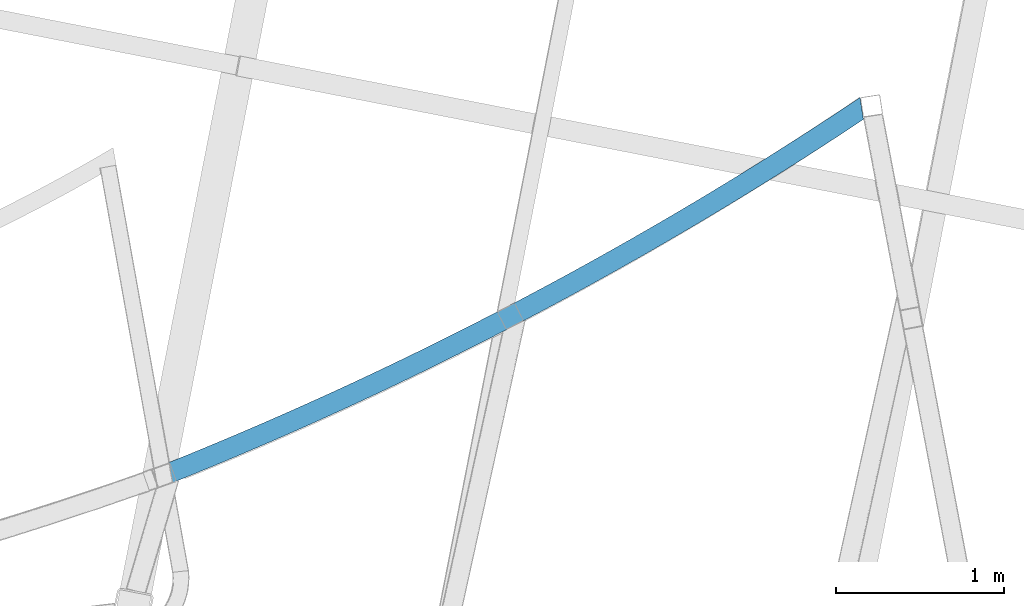
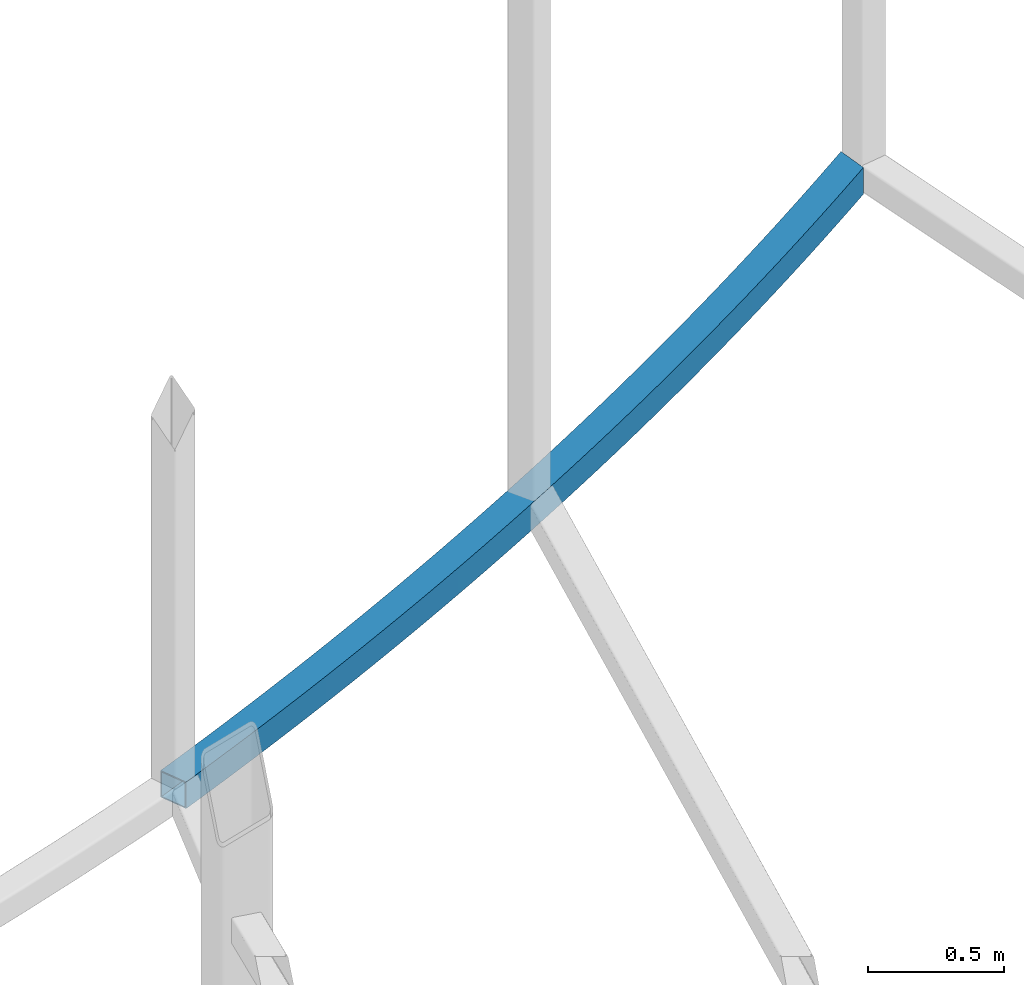
# One storey, part 211 of 215: 1 beam, 1 element without a shape of its own.
"""IFC2X3 building model written with IfcOpenShell, lengths in millimetres."""

from ifc_helpers import new_model, si_unit, frame, origin_with_axes, place, context, subcontext, project, spatial, faceted_brep, material, type_object, element, aggregate, save


model = new_model("IFC2X3")

# Units and contexts
model_context = context("Model", 3, precision=1e-05, world=origin_with_axes())
body_context = subcontext(model_context, "Body", "Model", "MODEL_VIEW")
ifc_project = project(units=[si_unit("LENGTHUNIT", "METRE", prefix="MILLI"), si_unit("AREAUNIT", "SQUARE_METRE"), si_unit("VOLUMEUNIT", "CUBIC_METRE"), si_unit("MASSUNIT", "GRAM", prefix="KILO"), si_unit("TIMEUNIT", "SECOND"), si_unit("PLANEANGLEUNIT", "RADIAN"), si_unit("SOLIDANGLEUNIT", "STERADIAN"), si_unit("THERMODYNAMICTEMPERATUREUNIT", "DEGREE_CELSIUS"), si_unit("LUMINOUSINTENSITYUNIT", "LUMEN")], contexts=[model_context])

# Site, building, storey
site_placement = place(None, origin_with_axes())
site = spatial("IfcSite", under=ifc_project, at=site_placement, CompositionType="ELEMENT")
building_placement = place(site_placement, origin_with_axes())
building = spatial("IfcBuilding", under=site, at=building_placement, Name="Undefined", CompositionType="ELEMENT")
storey_placement = place(building_placement, origin_with_axes())
storey = spatial("IfcBuildingStorey", under=building, at=storey_placement, Name="Undefined", CompositionType="ELEMENT", Elevation=0.0)

# Assembly, beam
assembly_placement = place(storey_placement, origin_with_axes())
assembly = element("IfcElementAssembly", 1, at=assembly_placement, inside=storey, Name="Steel Assembly", AssemblyPlace="NOTDEFINED", PredefinedType="RIGID_FRAME")
ifc_material = material(Name="STEEL/S275JR")
beam_type = type_object("IfcBeamType", PredefinedType="NOTDEFINED")
beam_placement = place(assembly_placement, frame((89086.1662001797, 7629.35720790217, 8706.00006129924), z_axis=(0.0, 0.0, -1.0), x_axis=(-0.884819292057938, -0.465934352030508, 6.99999985050166e-09)))
beam = element("IfcBeam", 2, at=beam_placement, type_object=beam_type, material=ifc_material, Name="LISSE", context=body_context, shape_type="Brep", body=[
    faceted_brep([(100.008088549963, 50.0191894137461, -60.0000000000018), (100.00808859081, 50.0191894137533, 59.9999999999982), (193.785047622063, 40.7596308906723, 60.0), (193.78504758123, 40.759630890665, -60.0), (287.59996438674, 31.8929031047883, 59.9999999999982), (287.599964345907, 31.8929031047883, -60.0000000000018), (381.451193328117, 23.4191615826057, 59.9999999999982), (381.451193287285, 23.4191615825985, -60.0000000000018), (475.337088252578, 15.3385549574232, 59.9999999999982), (475.337088211731, 15.3385549574159, -60.0000000000018), (569.256002358336, 7.65122496679396, 59.9999999999982), (569.256002317503, 7.65122496680124, -60.0000000000018), (663.20628826457, 0.357306450037868, 60.0), (663.206288223737, 0.357306450037868, -60.0), (757.18629804012, -6.54307265418902, 59.9999999999982), (757.186297999287, -6.54307265419629, -60.0000000000018), (851.194383232432, -13.0497913100626, 60.0), (851.194383191614, -13.0497913100626, -60.0), (945.228894896543, -19.1627353867516, 60.0), (945.228894855711, -19.1627353867516, -60.0), (1039.28818362394, -24.8817976603968, 59.9999999999982), (1039.28818358311, -24.8817976604041, -60.0000000000018), (1133.3705995715, -30.2068778160392, 59.9999999999982), (1133.37059953065, -30.2068778160465, -60.0000000000018), (1227.47449249044, -35.1378824493222, 59.9999999999982), (1227.4744924496, -35.1378824493149, -60.0000000000018), (1321.59821175526, -39.6747250681437, 60.0), (1321.59821171444, -39.6747250681437, -60.0), (1415.74010639274, -43.8173260942131, 59.9999999999982), (1415.74010635189, -43.8173260942203, -60.0000000000018), (1509.89852511077, -47.5656128644187, 60.0), (1509.89852506993, -47.5656128644187, -60.0), (1604.07181632749, -50.9195196320652, 60.0), (1604.07181628664, -50.9195196320725, -60.0), (1698.25832820007, -53.8789875681032, 60.0), (1698.25832815925, -53.8789875681032, -60.0), (1792.4564086539, -56.4439647621039, 59.9999999999982), (1792.45640861308, -56.4439647621039, -60.0000000000018), (1886.6644054114, -58.6144062231833, 60.0), (1886.66440537057, -58.6144062231833, -60.0), (1980.880666021, -60.3902738808101, 59.9999999999982), (1980.88066598016, -60.3902738808174, -60.0000000000018), (2075.10353788624, -61.7715365854383, 59.9999999999982), (2075.1035378454, -61.7715365854456, -60.0000000000018), (2169.33136829468, -62.7581701091112, 59.9999999999982), (2169.33136825384, -62.7581701091112, -60.0000000000018), (2263.56250444692, -63.3501571457964, 60.0), (2263.56250440607, -63.3501571457891, -60.0), (2357.79529348554, -63.547487311771, 60.0), (2357.79529344471, -63.5474873117782, -60.0), (2452.02808252416, -63.3501571457891, 60.0), (2452.02808248333, -63.3501571457964, -60.0), (2546.25921867639, -62.7581701091112, 59.9999999999982), (2546.25921863558, -62.7581701091112, -60.0000000000018), (2640.48704908486, -61.7715365854383, 59.9999999999982), (2640.48704904401, -61.7715365854456, -60.0000000000018), (2734.7099209501, -60.3902738808101, 59.9999999999982), (2734.70992090924, -60.3902738808174, -60.0000000000018), (2828.9261815597, -58.6144062231833, 59.9999999999982), (2828.92618151884, -58.6144062231906, -60.0000000000018), (2923.13417831717, -56.4439647621039, 60.0), (2923.13417827633, -56.4439647621039, -60.0), (3017.332258771, -53.8789875681105, 60.0), (3017.33225873017, -53.8789875681032, -60.0), (3111.5187706436, -50.9195196320652, 60.0), (3111.51877060278, -50.9195196320652, -60.0), (3205.69206186032, -47.5656128644114, 59.9999999999982), (3205.69206181949, -47.5656128644187, -60.0000000000018), (3299.85048057835, -43.8173260942131, 60.0), (3299.85048053751, -43.8173260942131, -60.0), (3393.99237521581, -39.6747250681437, 60.0), (3393.99237517497, -39.6747250681437, -60.0), (3488.11609448065, -35.1378824493149, 59.9999999999982), (3488.11609443981, -35.1378824493149, -60.0000000000018), (3582.21998739959, -30.2068778160392, 59.9999999999982), (3582.21998735875, -30.2068778160465, -60.0000000000018), (3676.30240334714, -24.8817976603968, 60.0), (3676.3024033063, -24.8817976604041, -60.0), (3770.36169207454, -19.1627353867443, 60.0), (3770.36169203369, -19.1627353867516, -60.0), (3864.39620373865, -13.0497913100626, 59.9999999999982), (3864.3962036978, -13.0497913100699, -60.0000000000018), (3958.40428893096, -6.54307265419629, 59.9999999999982), (3958.40428889013, -6.54307265419629, -60.0000000000018), (4052.38429870651, 0.357306450037868, 60.0), (4052.38429866567, 0.357306450030592, -60.0), (4146.33458461275, 7.65122496680124, 59.9999999999982), (4146.3345845719, 7.65122496680124, -60.0000000000018), (4240.25349871852, 15.3385549574232, 60.0), (4240.25349867767, 15.3385549574159, -60.0), (4334.13939364295, 23.4191615826057, 59.9999999999982), (4334.13939360212, 23.4191615825985, -60.0000000000018), (4427.99062258434, 31.8929031047883, 60.0), (4427.9906225435, 31.892903104781, -60.0), (4521.80553934902, 40.7596308906723, 59.9999999999982), (4521.80553930817, 40.759630890665, -60.0000000000018), (4615.58249838027, 50.0191894137533, 59.9999999999982), (4615.58249833946, 50.0191894137533, -60.0000000000018), (4533.34692732696, -78.6840644789263, 59.9999999999982), (4627.62403013972, -69.3751216437086, 59.9999999999982), (4439.03166433953, -87.5980814796567, 59.9999999999982), (4344.67989551046, -96.1170162899653, 59.9999999999982), (4250.29327581309, -104.240719483816, 60.0), (4155.8734608321, -111.969048567713, 60.0), (4061.42210673436, -119.301867983231, 59.9999999999982), (3966.94087024, -126.239049109354, 59.9999999999982), (3872.43140859333, -132.780470264719, 59.9999999999982), (3777.89537953369, -138.926016709811, 59.9999999999982), (3683.33444126642, -144.675580648924, 60.0), (3588.75025243381, -150.02906123206, 59.9999999999982), (3494.14447208596, -154.986364556717, 59.9999999999982), (3399.51875965172, -159.547403669509, 60.0), (3304.87477490951, -163.712098567725, 59.9999999999982), (3210.21417795832, -167.4803762007, 59.9999999999982), (3115.53862918845, -170.852170471109, 60.0), (3020.84978925253, -173.827422236136, 60.0), (2926.14931903627, -176.406079308501, 60.0), (2831.43887962942, -178.588096457373, 59.9999999999982), (2736.72013229658, -180.373435409179, 59.9999999999982), (2641.99473844805, -181.762064848241, 59.9999999999982), (2547.26435961077, -182.753960417358, 60.0), (2452.53065739904, -183.34910471824, 59.9999999999982), (2357.79529348554, -183.547487311778, 59.9999999999982), (2263.05992957203, -183.349104718247, 59.9999999999982), (2168.32622736033, -182.753960417358, 60.0), (2073.59584852302, -181.762064848241, 60.0), (1978.87045467451, -180.373435409172, 59.9999999999982), (1884.15170734168, -178.588096457381, 60.0), (1789.44126793482, -176.406079308508, 60.0), (1694.74079771856, -173.827422236136, 59.9999999999982), (1600.05195778262, -170.852170471109, 59.9999999999982), (1505.37640901278, -167.4803762007, 59.9999999999982), (1410.71581206158, -163.712098567725, 59.9999999999982), (1316.07182731938, -159.547403669509, 59.9999999999982), (1221.44611488513, -154.986364556717, 60.0), (1126.84033453729, -150.029061232053, 59.9999999999982), (1032.25614570468, -144.675580648924, 60.0), (937.695207437413, -138.926016709811, 59.9999999999982), (843.159178377755, -132.780470264726, 59.9999999999982), (748.649716731074, -126.239049109347, 59.9999999999982), (654.168480236724, -119.301867983231, 59.9999999999982), (559.717126139003, -111.969048567713, 59.9999999999982), (465.297311157992, -104.240719483809, 59.9999999999982), (370.910691460624, -96.1170162899653, 60.0), (276.55892263155, -87.5980814796567, 60.0), (182.243659644126, -78.684064478919, 59.9999999999982), (87.9665568313649, -69.3751216437158, 60.0), (87.9665567905322, -69.3751216437086, -60.0), (182.243659603293, -78.684064478919, -60.0000000000018), (276.558922590717, -87.5980814796567, -60.0), (370.910691419791, -96.117016289958, -60.0), (465.29731111716, -104.240719483816, -60.0000000000018), (559.717126098156, -111.96904856772, -60.0000000000018), (654.168480195891, -119.301867983231, -60.0000000000018), (748.649716690241, -126.239049109354, -60.0000000000018), (843.159178336922, -132.780470264726, -60.0000000000018), (937.695207396566, -138.926016709818, -60.0000000000018), (1032.25614566384, -144.675580648931, -60.0), (1126.84033449645, -150.029061232068, -60.0000000000018), (1221.44611484431, -154.986364556717, -60.0), (1316.07182727855, -159.547403669516, -60.0000000000018), (1410.71581202073, -163.712098567732, -60.0000000000018), (1505.37640897193, -167.480376200692, -60.0000000000018), (1600.0519577418, -170.852170471109, -60.0000000000018), (1694.74079767773, -173.827422236136, -60.0000000000018), (1789.44126789398, -176.406079308508, -60.0), (1884.15170730083, -178.588096457388, -60.0), (1978.87045463368, -180.373435409179, -60.0000000000018), (2073.5958484822, -181.762064848241, -60.0), (2168.3262273195, -182.753960417365, -60.0), (2263.05992953121, -183.349104718247, -60.0000000000018), (2357.79529344471, -183.547487311786, -60.0000000000018), (2452.53065735822, -183.34910471824, -60.0000000000018), (2547.2643595699, -182.753960417365, -60.0), (2641.99473840721, -181.762064848241, -60.0000000000018), (2736.72013225574, -180.373435409187, -60.0000000000018), (2831.43887958859, -178.588096457381, -60.0000000000018), (2926.14931899543, -176.406079308501, -60.0), (3020.84978921169, -173.827422236143, -60.0), (3115.53862914762, -170.852170471109, -60.0), (3210.21417791747, -167.4803762007, -60.0000000000018), (3304.87477486869, -163.712098567717, -60.0000000000018), (3399.51875961086, -159.547403669516, -60.0), (3494.14447204511, -154.986364556717, -60.0000000000018), (3588.75025239296, -150.029061232068, -60.0000000000018), (3683.33444122557, -144.675580648931, -60.0), (3777.89537949284, -138.926016709818, -60.0000000000018), (3872.43140855248, -132.780470264726, -60.0000000000018), (3966.94087019918, -126.239049109354, -60.0000000000018), (4061.42210669351, -119.301867983238, -60.0000000000018), (4155.87346079125, -111.96904856772, -60.0), (4250.29327577226, -104.240719483816, -60.0), (4344.67989546963, -96.1170162899653, -60.0000000000018), (4439.03166429869, -87.598081479664, -60.0000000000018), (4533.34692728613, -78.684064478919, -60.0000000000018), (4627.62403009889, -69.3751216437158, -60.0000000000018), (4721.86131907329, -59.6714162571589, -60.0000000000018), (4721.86131911415, -59.6714162571516, 59.9999999999982), (4709.31985478719, 59.6714162571516, 59.9999999999982), (4709.31985474635, 59.6714162571443, -60.0000000000018), (99.5063580991264, 45.0444264530233, 55.0), (88.4682873196434, -64.4003586829858, 55.0), (47.6512828940467, -60.1973920015589, 55.0), (8.13784636146738, 54.4527310547419, 54.9999999999982), (88.4682872822159, -64.4003586829858, -55.0), (47.6512828953855, -60.1973920055389, -55.0), (99.5063580616843, 45.0444264530233, -55.0), (8.13784636282071, 54.4527310507401, -55.0000000000018), (193.304156417173, 35.7828102502681, -55.0000000000018), (193.304156454615, 35.7828102502608, 54.9999999999982), (182.724550808169, -73.7072438385148, 55.0), (182.724550770712, -73.7072438385221, -55.0), (277.018965998883, -82.61929045531, -55.0000000000018), (287.139920941132, 26.9141120804343, -55.0), (287.139920978574, 26.9141120804343, 55.0), (277.01896603631, -82.61929045531, 54.9999999999982), (371.34987903673, -91.1363422119393, 55.0), (371.349878999288, -91.1363422119393, -55.0), (381.012005711164, 18.4384875045798, -55.0000000000018), (381.012005748606, 18.4384875045725, 54.9999999999982), (474.918764205242, 10.3560851890361, 54.9999999999982), (465.715635201894, -99.2582497154217, 54.9999999999982), (465.715635164437, -99.258249715429, -55.0000000000018), (474.918764167815, 10.3560851890361, -55.0000000000018), (568.858549143377, 2.66704690286133, -55.0000000000018), (568.858549180834, 2.66704690286133, 54.9999999999982), (560.1145793131, -106.98487050378, 54.9999999999982), (560.114579275658, -106.98487050378, -55.0000000000018), (654.545055532071, -114.316069048509, -55.0000000000018), (662.829712890947, -4.62849248467683, -55.0000000000018), (662.829712928375, -4.62849248467683, 54.9999999999982), (654.545055569513, -114.316069048517, 54.9999999999982), (749.005407617253, -121.251716757055, 55.0), (749.005407579811, -121.251716757055, -55.0), (756.830607113094, -11.5304050064951, -55.0), (756.830607150536, -11.5304050064951, 55.0), (850.859583028447, -18.0385695998411, 55.0), (843.493978578321, -127.791691974948, 55.0), (843.493978540893, -127.79169197494, -55.0), (850.859582991005, -18.0385695998411, -55.0), (944.914991213271, -24.1528721085415, -55.0000000000018), (944.914991250727, -24.1528721085415, 54.9999999999982), (938.009111079824, -133.935879988021, 54.9999999999982), (938.009111042396, -133.935879988021, -55.0000000000018), (1032.5491472455, -139.684173024412, -55.0000000000018), (1038.99518200482, -29.8732052849227, -55.0000000000018), (1038.99518204226, -29.8732052849227, 54.9999999999982), (1032.54914728295, -139.684173024405, 54.9999999999982), (1127.11242891201, -145.036470256397, 55.0), (1127.11242887458, -145.036470256397, -55.0), (1133.09850515594, -35.1994687917104, -55.0), (1133.09850519337, -35.1994687917104, 55.0), (1227.22331008851, -40.131569203797, 55.0), (1221.69729728365, -149.992677802242, 54.9999999999982), (1221.6972972462, -149.992677802242, -55.0000000000018), (1227.22331005106, -40.1315692037897, -55.0), (1321.36794569796, -44.6694200098646, -55.0), (1321.36794573542, -44.6694200098646, 55.0), (1316.30209333583, -154.552708727788, 55.0), (1316.30209329839, -154.552708727788, -55.0), (1410.92515761955, -158.716483047996, -55.0000000000018), (1415.53076075646, -48.8129416139491, -55.0000000000018), (1415.5307607939, -48.8129416139491, 54.9999999999982), (1410.925157657, -158.716483047996, 54.9999999999982), (1505.56483051516, -162.483927728354, 55.0), (1505.5648304777, -162.483927728361, -55.0), (1509.71010356754, -52.5620613367646, -55.0000000000018), (1509.710103605, -52.5620613367573, 54.9999999999982), (1603.90432221974, -55.9167134170275, 55.0), (1600.21945188697, -165.854976686147, 54.9999999999982), (1600.21945184952, -165.854976686154, -55.0000000000018), (1603.90432218229, -55.9167134170275, -55.0), (1698.11176439088, -58.8768390126133, -55.0), (1698.11176442832, -58.8768390126061, 55.0), (1694.88736148692, -168.829570791633, 54.9999999999982), (1694.88736144948, -168.82957079164, -55.0000000000018), (1789.56689875896, -171.407657869066, -55.0000000000018), (1792.33077775147, -61.4423862015392, -55.0), (1792.33077778891, -61.4423862015392, 55.0), (1789.56689879642, -171.407657869073, 54.9999999999982), (1884.25640309288, -173.589192697626, 54.9999999999982), (1884.25640305543, -173.589192697618, -55.0000000000018), (1886.55970961934, -63.6133099829458, -55.0000000000018), (1886.55970965679, -63.6133099829458, 54.9999999999982), (1980.7969072132, -65.3895722778252, 55.0), (1978.95421347891, -175.374137012164, 55.0), (1978.95421344147, -175.374137012164, -55.0), (1980.79690717574, -65.3895722778252, -55.0), (2075.04071745696, -66.7711419297266, -55.0000000000018), (2075.0407174944, -66.7711419297266, 54.9999999999982), (2073.65866891146, -176.762459503967, 54.9999999999982), (2073.65866887402, -176.76245950396, -55.0000000000018), (2168.36810819343, -177.754135821189, -55.0), (2169.28948738327, -67.7579947052873, -55.0000000000018), (2169.2894874207, -67.7579947052873, 54.9999999999982), (2168.36810823089, -177.754135821182, 55.0), (2263.08087019013, -178.349148569388, 55.0), (2263.08087015268, -178.349148569388, -55.0), (2263.54156378799, -68.3501132946403, -55.0), (2263.54156382543, -68.3501132946476, 55.0), (2357.79529348384, -68.5474873117782, 55.0), (2357.79529348384, -178.547487311771, 54.9999999999982), (2357.7952934464, -178.547487311778, -55.0000000000018), (2357.7952934464, -68.5474873117855, -55.0), (2452.04902310482, -68.3501132946403, -55.0000000000018), (2452.04902314226, -68.3501132946403, 54.9999999999982), (2452.50971677755, -178.349148569388, 55.0), (2452.5097167401, -178.349148569388, -55.0), (2547.22247869936, -177.754135821182, -55.0), (2546.30109950954, -67.75799470528, -55.0000000000018), (2546.30109954697, -67.7579947052946, 54.9999999999982), (2547.22247873679, -177.754135821189, 55.0), (2641.93191805622, -176.76245950396, 55.0), (2641.93191801876, -176.76245950396, -55.0), (2640.54986943582, -66.7711419297266, -55.0), (2640.54986947328, -66.7711419297339, 55.0), (2734.79367975448, -65.3895722778252, 54.9999999999982), (2736.63637348876, -175.374137012164, 54.9999999999982), (2736.63637345131, -175.374137012164, -55.0000000000018), (2734.79367971706, -65.3895722778252, -55.0000000000018), (2829.03087727344, -63.6133099829531, -55.0000000000018), (2829.0308773109, -63.6133099829458, 54.9999999999982), (2831.3341838748, -173.589192697626, 54.9999999999982), (2831.33418383737, -173.589192697618, -55.0000000000018), (2926.02368813384, -171.407657869066, -55.0000000000018), (2923.25980914131, -61.4423862015392, -55.0000000000018), (2923.25980917877, -61.4423862015319, 54.9999999999982), (2926.02368817128, -171.407657869073, 54.9999999999982), (3020.70322548074, -168.82957079164, 54.9999999999982), (3020.70322544331, -168.82957079164, -55.0000000000018), (3017.47882250191, -58.8768390126133, -55.0), (3017.47882253936, -58.8768390126061, 55.0), (3111.68626474794, -55.9167134170275, 55.0), (3115.37113508071, -165.854976686154, 54.9999999999982), (3115.37113504326, -165.854976686154, -55.0000000000018), (3111.6862647105, -55.9167134170275, -55.0), (3205.88048332525, -52.5620613367573, -55.0), (3205.88048336269, -52.5620613367573, 55.0), (3210.02575645251, -162.483927728361, 55.0), (3210.02575641508, -162.483927728354, -55.0), (3304.66542927324, -158.716483047996, -55.0000000000018), (3300.05982613635, -48.8129416139491, -55.0000000000018), (3300.05982617378, -48.8129416139491, 54.9999999999982), (3304.66542931067, -158.716483047996, 54.9999999999982), (3399.28849363184, -154.552708727788, 55.0), (3399.2884935944, -154.552708727781, -55.0), (3394.22264119484, -44.6694200098646, -55.0), (3394.22264123228, -44.6694200098646, 55.0), (3488.36727687916, -40.1315692037897, 54.9999999999982), (3493.89328968403, -149.992677802242, 55.0), (3493.89328964658, -149.992677802242, -55.0), (3488.36727684172, -40.131569203797, -55.0000000000018), (3582.49208173687, -35.1994687917104, -55.0000000000018), (3582.4920817743, -35.1994687917104, 54.9999999999982), (3588.47815805566, -145.036470256389, 54.9999999999982), (3588.47815801822, -145.036470256397, -55.0000000000018), (3683.04143964731, -139.684173024405, -55.0), (3676.59540488796, -29.87320528493, -55.0000000000018), (3676.59540492541, -29.87320528493, 54.9999999999982), (3683.04143968473, -139.684173024405, 55.0), (3777.58147588784, -133.935879988021, 54.9999999999982), (3777.5814758504, -133.935879988021, -55.0000000000018), (3770.67559567951, -24.1528721085488, -55.0000000000018), (3770.67559571697, -24.1528721085415, 54.9999999999982), (3864.73100393923, -18.0385695998339, 54.9999999999982), (3872.09660838936, -127.79169197494, 54.9999999999982), (3872.0966083519, -127.791691974948, -55.0000000000018), (3864.73100390179, -18.0385695998411, -55.0000000000018), (3958.7599797797, -11.5304050064951, -55.0), (3958.75997981713, -11.5304050064951, 55.0), (3966.58517935044, -121.251716757055, 55.0), (3966.58517931298, -121.251716757055, -55.0), (4061.04553136071, -114.316069048509, -55.0), (4052.76087400185, -4.62849248467683, -55.0000000000018), (4052.7608740393, -4.6284924846841, 54.9999999999982), (4061.04553139815, -114.316069048517, 55.0), (4155.47600765459, -106.98487050378, 55.0), (4155.47600761714, -106.984870503773, -55.0), (4146.73203774939, 2.66704690286133, -55.0000000000018), (4146.73203778685, 2.66704690285405, 54.9999999999982), (4240.67182276242, 10.3560851890434, 54.9999999999982), (4249.87495176579, -99.2582497154217, 54.9999999999982), (4249.87495172833, -99.258249715429, -55.0000000000018), (4240.67182272498, 10.3560851890361, -55.0000000000018), (4334.57858118162, 18.4384875045798, -55.0000000000018), (4334.57858121907, 18.4384875045725, 55.0), (4344.24070793093, -91.1363422119466, 54.9999999999982), (4344.24070789351, -91.1363422119393, -55.0000000000018), (4438.57162089393, -82.61929045531, -55.0000000000018), (4428.45066595166, 26.9141120804343, -55.0000000000018), (4428.45066598909, 26.9141120804343, 54.9999999999982), (4438.57162093137, -82.61929045531, 54.9999999999982), (4532.86603615951, -73.7072438385221, 54.9999999999982), (4532.86603612207, -73.7072438385221, -55.0000000000018), (4522.28643047564, 35.7828102502681, -55.0000000000018), (4522.28643051306, 35.7828102502681, 54.9999999999982), (4616.08422886855, 45.0444264530306, 55.0), (4627.12229964804, -64.4003586829858, 54.9999999999982), (4627.12229961059, -64.4003586829858, -55.0000000000018), (4616.08422883111, 45.0444264530306, -55.0), (4709.84241576167, 54.6987982357168, -55.0000000000018), (4709.8424157991, 54.6987982357168, 54.9999999999982), (4721.33875809879, -54.6987982357241, 55.0), (4721.33875806136, -54.6987982357241, -55.0), (49.4473481923924, -65.4087612355579, -60.0000000000018), (6.27073214304983, 59.6714162571443, -60.0), (6.27073218389705, 59.6714162571516, 60.0), (49.4473481909226, -65.4087612311996, 59.9999999999982)], [[[0, 1, 2, 3]], [[3, 2, 4, 5]], [[5, 4, 6, 7]], [[7, 6, 8, 9]], [[9, 8, 10, 11]], [[11, 10, 12, 13]], [[13, 12, 14, 15]], [[15, 14, 16, 17]], [[17, 16, 18, 19]], [[19, 18, 20, 21]], [[21, 20, 22, 23]], [[23, 22, 24, 25]], [[25, 24, 26, 27]], [[27, 26, 28, 29]], [[29, 28, 30, 31]], [[31, 30, 32, 33]], [[33, 32, 34, 35]], [[35, 34, 36, 37]], [[37, 36, 38, 39]], [[39, 38, 40, 41]], [[41, 40, 42, 43]], [[43, 42, 44, 45]], [[45, 44, 46, 47]], [[47, 46, 48, 49]], [[49, 48, 50, 51]], [[51, 50, 52, 53]], [[53, 52, 54, 55]], [[55, 54, 56, 57]], [[57, 56, 58, 59]], [[59, 58, 60, 61]], [[61, 60, 62, 63]], [[63, 62, 64, 65]], [[65, 64, 66, 67]], [[67, 66, 68, 69]], [[69, 68, 70, 71]], [[71, 70, 72, 73]], [[73, 72, 74, 75]], [[75, 74, 76, 77]], [[77, 76, 78, 79]], [[79, 78, 80, 81]], [[81, 80, 82, 83]], [[83, 82, 84, 85]], [[85, 84, 86, 87]], [[87, 86, 88, 89]], [[89, 88, 90, 91]], [[91, 90, 92, 93]], [[93, 92, 94, 95]], [[95, 94, 96, 97]], [[94, 98, 99, 96]], [[92, 100, 98, 94]], [[90, 101, 100, 92]], [[88, 102, 101, 90]], [[86, 103, 102, 88]], [[84, 104, 103, 86]], [[82, 105, 104, 84]], [[80, 106, 105, 82]], [[78, 107, 106, 80]], [[76, 108, 107, 78]], [[74, 109, 108, 76]], [[72, 110, 109, 74]], [[70, 111, 110, 72]], [[68, 112, 111, 70]], [[66, 113, 112, 68]], [[64, 114, 113, 66]], [[62, 115, 114, 64]], [[60, 116, 115, 62]], [[58, 117, 116, 60]], [[56, 118, 117, 58]], [[54, 119, 118, 56]], [[52, 120, 119, 54]], [[50, 121, 120, 52]], [[48, 122, 121, 50]], [[46, 123, 122, 48]], [[44, 124, 123, 46]], [[42, 125, 124, 44]], [[40, 126, 125, 42]], [[38, 127, 126, 40]], [[36, 128, 127, 38]], [[34, 129, 128, 36]], [[32, 130, 129, 34]], [[30, 131, 130, 32]], [[28, 132, 131, 30]], [[26, 133, 132, 28]], [[24, 134, 133, 26]], [[22, 135, 134, 24]], [[20, 136, 135, 22]], [[18, 137, 136, 20]], [[16, 138, 137, 18]], [[14, 139, 138, 16]], [[12, 140, 139, 14]], [[10, 141, 140, 12]], [[8, 142, 141, 10]], [[6, 143, 142, 8]], [[4, 144, 143, 6]], [[2, 145, 144, 4]], [[1, 146, 145, 2]], [[146, 147, 148, 145]], [[145, 148, 149, 144]], [[144, 149, 150, 143]], [[143, 150, 151, 142]], [[142, 151, 152, 141]], [[141, 152, 153, 140]], [[140, 153, 154, 139]], [[139, 154, 155, 138]], [[138, 155, 156, 137]], [[137, 156, 157, 136]], [[136, 157, 158, 135]], [[135, 158, 159, 134]], [[134, 159, 160, 133]], [[133, 160, 161, 132]], [[132, 161, 162, 131]], [[131, 162, 163, 130]], [[130, 163, 164, 129]], [[129, 164, 165, 128]], [[128, 165, 166, 127]], [[127, 166, 167, 126]], [[126, 167, 168, 125]], [[125, 168, 169, 124]], [[124, 169, 170, 123]], [[123, 170, 171, 122]], [[122, 171, 172, 121]], [[121, 172, 173, 120]], [[120, 173, 174, 119]], [[119, 174, 175, 118]], [[118, 175, 176, 117]], [[117, 176, 177, 116]], [[116, 177, 178, 115]], [[115, 178, 179, 114]], [[114, 179, 180, 113]], [[113, 180, 181, 112]], [[112, 181, 182, 111]], [[111, 182, 183, 110]], [[110, 183, 184, 109]], [[109, 184, 185, 108]], [[108, 185, 186, 107]], [[107, 186, 187, 106]], [[106, 187, 188, 105]], [[105, 188, 189, 104]], [[104, 189, 190, 103]], [[103, 190, 191, 102]], [[102, 191, 192, 101]], [[101, 192, 193, 100]], [[100, 193, 194, 98]], [[98, 194, 195, 99]], [[99, 195, 196, 197]], [[96, 99, 197, 198]], [[97, 96, 198, 199]], [[200, 201, 202, 203]], [[201, 204, 205, 202]], [[204, 206, 207, 205]], [[203, 202, 205, 207]], [[206, 200, 203, 207]], [[200, 206, 208, 209]], [[201, 200, 209, 210]], [[204, 201, 210, 211]], [[206, 204, 211, 208]], [[208, 211, 212, 213]], [[209, 208, 213, 214]], [[210, 209, 214, 215]], [[211, 210, 215, 212]], [[212, 215, 216, 217]], [[213, 212, 217, 218]], [[214, 213, 218, 219]], [[215, 214, 219, 216]], [[216, 219, 220, 221]], [[217, 216, 221, 222]], [[218, 217, 222, 223]], [[219, 218, 223, 220]], [[220, 223, 224, 225]], [[221, 220, 225, 226]], [[222, 221, 226, 227]], [[223, 222, 227, 224]], [[224, 227, 228, 229]], [[225, 224, 229, 230]], [[226, 225, 230, 231]], [[227, 226, 231, 228]], [[228, 231, 232, 233]], [[229, 228, 233, 234]], [[230, 229, 234, 235]], [[231, 230, 235, 232]], [[232, 235, 236, 237]], [[233, 232, 237, 238]], [[234, 233, 238, 239]], [[235, 234, 239, 236]], [[236, 239, 240, 241]], [[237, 236, 241, 242]], [[238, 237, 242, 243]], [[239, 238, 243, 240]], [[240, 243, 244, 245]], [[241, 240, 245, 246]], [[242, 241, 246, 247]], [[243, 242, 247, 244]], [[244, 247, 248, 249]], [[245, 244, 249, 250]], [[246, 245, 250, 251]], [[247, 246, 251, 248]], [[248, 251, 252, 253]], [[249, 248, 253, 254]], [[250, 249, 254, 255]], [[251, 250, 255, 252]], [[252, 255, 256, 257]], [[253, 252, 257, 258]], [[254, 253, 258, 259]], [[255, 254, 259, 256]], [[256, 259, 260, 261]], [[257, 256, 261, 262]], [[258, 257, 262, 263]], [[259, 258, 263, 260]], [[260, 263, 264, 265]], [[261, 260, 265, 266]], [[262, 261, 266, 267]], [[263, 262, 267, 264]], [[264, 267, 268, 269]], [[265, 264, 269, 270]], [[266, 265, 270, 271]], [[267, 266, 271, 268]], [[268, 271, 272, 273]], [[269, 268, 273, 274]], [[270, 269, 274, 275]], [[271, 270, 275, 272]], [[272, 275, 276, 277]], [[273, 272, 277, 278]], [[274, 273, 278, 279]], [[275, 274, 279, 276]], [[276, 279, 280, 281]], [[277, 276, 281, 282]], [[278, 277, 282, 283]], [[279, 278, 283, 280]], [[280, 283, 284, 285]], [[281, 280, 285, 286]], [[282, 281, 286, 287]], [[283, 282, 287, 284]], [[284, 287, 288, 289]], [[285, 284, 289, 290]], [[286, 285, 290, 291]], [[287, 286, 291, 288]], [[288, 291, 292, 293]], [[289, 288, 293, 294]], [[290, 289, 294, 295]], [[291, 290, 295, 292]], [[292, 295, 296, 297]], [[293, 292, 297, 298]], [[294, 293, 298, 299]], [[295, 294, 299, 296]], [[296, 299, 300, 301]], [[297, 296, 301, 302]], [[298, 297, 302, 303]], [[299, 298, 303, 300]], [[300, 303, 304, 305]], [[301, 300, 305, 306]], [[302, 301, 306, 307]], [[303, 302, 307, 304]], [[304, 307, 308, 309]], [[305, 304, 309, 310]], [[306, 305, 310, 311]], [[307, 306, 311, 308]], [[308, 311, 312, 313]], [[309, 308, 313, 314]], [[310, 309, 314, 315]], [[311, 310, 315, 312]], [[312, 315, 316, 317]], [[313, 312, 317, 318]], [[314, 313, 318, 319]], [[315, 314, 319, 316]], [[316, 319, 320, 321]], [[317, 316, 321, 322]], [[318, 317, 322, 323]], [[319, 318, 323, 320]], [[320, 323, 324, 325]], [[321, 320, 325, 326]], [[322, 321, 326, 327]], [[323, 322, 327, 324]], [[324, 327, 328, 329]], [[325, 324, 329, 330]], [[326, 325, 330, 331]], [[327, 326, 331, 328]], [[328, 331, 332, 333]], [[329, 328, 333, 334]], [[330, 329, 334, 335]], [[331, 330, 335, 332]], [[332, 335, 336, 337]], [[333, 332, 337, 338]], [[334, 333, 338, 339]], [[335, 334, 339, 336]], [[336, 339, 340, 341]], [[337, 336, 341, 342]], [[338, 337, 342, 343]], [[339, 338, 343, 340]], [[340, 343, 344, 345]], [[341, 340, 345, 346]], [[342, 341, 346, 347]], [[343, 342, 347, 344]], [[344, 347, 348, 349]], [[345, 344, 349, 350]], [[346, 345, 350, 351]], [[347, 346, 351, 348]], [[348, 351, 352, 353]], [[349, 348, 353, 354]], [[350, 349, 354, 355]], [[351, 350, 355, 352]], [[352, 355, 356, 357]], [[353, 352, 357, 358]], [[354, 353, 358, 359]], [[355, 354, 359, 356]], [[356, 359, 360, 361]], [[357, 356, 361, 362]], [[358, 357, 362, 363]], [[359, 358, 363, 360]], [[360, 363, 364, 365]], [[361, 360, 365, 366]], [[362, 361, 366, 367]], [[363, 362, 367, 364]], [[364, 367, 368, 369]], [[365, 364, 369, 370]], [[366, 365, 370, 371]], [[367, 366, 371, 368]], [[368, 371, 372, 373]], [[369, 368, 373, 374]], [[370, 369, 374, 375]], [[371, 370, 375, 372]], [[372, 375, 376, 377]], [[373, 372, 377, 378]], [[374, 373, 378, 379]], [[375, 374, 379, 376]], [[376, 379, 380, 381]], [[377, 376, 381, 382]], [[378, 377, 382, 383]], [[379, 378, 383, 380]], [[380, 383, 384, 385]], [[381, 380, 385, 386]], [[382, 381, 386, 387]], [[383, 382, 387, 384]], [[384, 387, 388, 389]], [[385, 384, 389, 390]], [[386, 385, 390, 391]], [[387, 386, 391, 388]], [[388, 391, 392, 393]], [[389, 388, 393, 394]], [[390, 389, 394, 395]], [[391, 390, 395, 392]], [[392, 395, 396, 397]], [[393, 392, 397, 398]], [[394, 393, 398, 399]], [[395, 394, 399, 396]], [[396, 399, 400, 401]], [[397, 396, 401, 402]], [[398, 397, 402, 403]], [[399, 398, 403, 400]], [[197, 196, 199, 198], [402, 401, 400, 403]], [[195, 97, 199, 196]], [[194, 95, 97, 195]], [[193, 93, 95, 194]], [[192, 91, 93, 193]], [[191, 89, 91, 192]], [[190, 87, 89, 191]], [[189, 85, 87, 190]], [[188, 83, 85, 189]], [[187, 81, 83, 188]], [[186, 79, 81, 187]], [[185, 77, 79, 186]], [[184, 75, 77, 185]], [[183, 73, 75, 184]], [[182, 71, 73, 183]], [[181, 69, 71, 182]], [[180, 67, 69, 181]], [[179, 65, 67, 180]], [[178, 63, 65, 179]], [[177, 61, 63, 178]], [[176, 59, 61, 177]], [[175, 57, 59, 176]], [[174, 55, 57, 175]], [[173, 53, 55, 174]], [[172, 51, 53, 173]], [[171, 49, 51, 172]], [[170, 47, 49, 171]], [[169, 45, 47, 170]], [[168, 43, 45, 169]], [[167, 41, 43, 168]], [[166, 39, 41, 167]], [[165, 37, 39, 166]], [[164, 35, 37, 165]], [[163, 33, 35, 164]], [[162, 31, 33, 163]], [[161, 29, 31, 162]], [[160, 27, 29, 161]], [[159, 25, 27, 160]], [[158, 23, 25, 159]], [[157, 21, 23, 158]], [[156, 19, 21, 157]], [[155, 17, 19, 156]], [[154, 15, 17, 155]], [[153, 13, 15, 154]], [[152, 11, 13, 153]], [[151, 9, 11, 152]], [[150, 7, 9, 151]], [[149, 5, 7, 150]], [[148, 3, 5, 149]], [[147, 0, 3, 148]], [[0, 147, 404, 405]], [[1, 0, 405, 406]], [[146, 1, 406, 407]], [[147, 146, 407, 404]], [[406, 405, 404, 407]]]),
])
aggregate(assembly, [beam])

save(model, "model.ifc")
